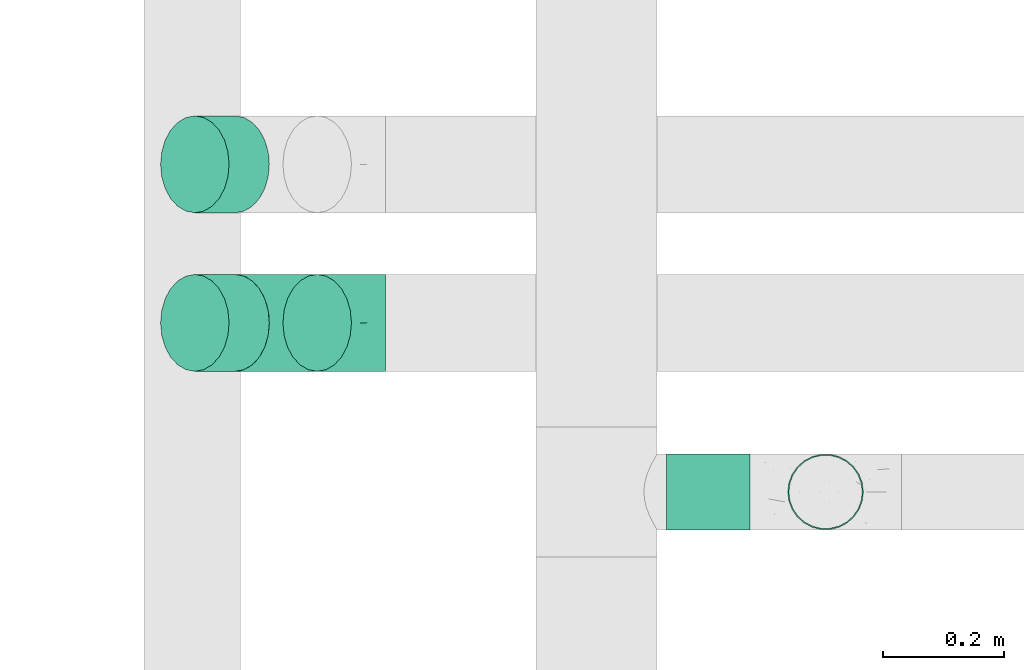
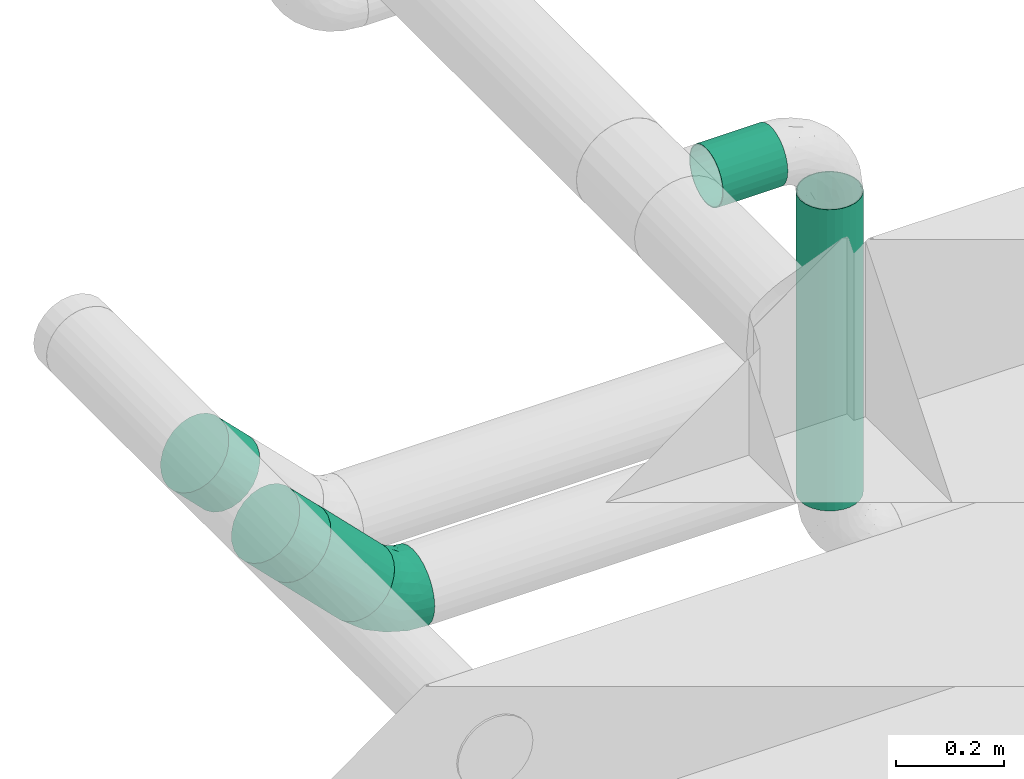
# One storey, part 62 of 91: 3 flow fittings, 3 flow segments.
"""IFC2X3 building model written with IfcOpenShell, lengths in millimetres."""

import ifcopenshell
import ifcopenshell.guid

model = None  # the IFC model being written
_history = None  # IfcOwnerHistory: only IFC2X3 demands one
_inside = {}  # id of a spatial element -> (the spatial element, [elements in it])
_under = {}  # id of a project, library or spatial element -> (it, [spatial elements below it])
_declared = {}  # id of a project -> (the project, [libraries it declares])
_typed = {}  # id of a type object -> (the type object, [elements of that type])
_made_of = {}  # id of a material, layer set ... -> (it, [elements and type objects made of it])


def new_model(schema):
    """Start an empty IFC model of exactly this schema.

    Asked for "IFC4X3", IfcOpenShell would pick the latest addendum, in which some entities
    have other attributes; the version numbers below select the first issue.
    IFC2X3 requires an IfcOwnerHistory on every rooted entity: one is made here for all.
    """
    global model, _history
    if schema == "IFC4X3":
        model = ifcopenshell.file(schema_version=(4, 3, 0, 0))
    else:
        model = ifcopenshell.file(schema=schema)
    _inside.clear()
    _under.clear()
    _declared.clear()
    _typed.clear()
    _made_of.clear()
    _history = None
    if model.schema == "IFC2X3":
        org = make("IfcOrganization", Name="unknown")
        user = make(
            "IfcPersonAndOrganization",
            ThePerson=make("IfcPerson", FamilyName="unknown"),
            TheOrganization=org,
        )
        app = make(
            "IfcApplication",
            ApplicationDeveloper=org,
            Version="unknown",
            ApplicationFullName="unknown",
            ApplicationIdentifier="unknown",
        )
        _history = make(
            "IfcOwnerHistory",
            OwningUser=user,
            OwningApplication=app,
            ChangeAction="ADDED",
            CreationDate=0,
        )
    return model


def make(cls, **values):
    """One entity of the class cls with the attributes given. An attribute that is None is left unset."""
    return model.create_entity(
        cls, **{name: value for name, value in values.items() if value is not None}
    )


def entity(cls, *values):
    """Any entity or typed value of the class cls, its attributes in the order of the schema. None: left unset."""
    e = model.create_entity(cls)
    for i, value in enumerate(values):
        if value is not None:
            e[i] = value
    return e


def rooted(cls, **values):
    """An entity with a GlobalId (a new one), such as an element, a storey or a relation."""
    return make(cls, GlobalId=ifcopenshell.guid.new(), OwnerHistory=_history, **values)


def si_unit(unit_type, name, prefix=None):
    """IfcSIUnit, for example si_unit("LENGTHUNIT", "METRE", prefix="MILLI")."""
    return make("IfcSIUnit", UnitType=unit_type, Prefix=prefix, Name=name)


def converted_unit(unit_type, name, factor, base, dimensions=None, offset=None):
    """IfcConversionBasedUnit, such as the inch: factor (a typed value) times the base unit."""
    return make(
        "IfcConversionBasedUnit"
        if offset is None
        else "IfcConversionBasedUnitWithOffset",
        ConversionOffset=offset,
        Dimensions=None
        if dimensions is None
        else entity("IfcDimensionalExponents", *dimensions),
        UnitType=unit_type,
        Name=name,
        ConversionFactor=make(
            "IfcMeasureWithUnit", ValueComponent=factor, UnitComponent=base
        ),
    )


def derived_unit(unit_type, elements):
    """IfcDerivedUnit: a product of units, each with its exponent."""
    return make(
        "IfcDerivedUnit",
        Elements=[
            make("IfcDerivedUnitElement", Unit=unit, Exponent=power)
            for unit, power in elements
        ],
        UnitType=unit_type,
    )


def assignment(units):
    """IfcUnitAssignment: the units of a project."""
    return None if units is None else make("IfcUnitAssignment", Units=units)


def point(xyz):
    """IfcCartesianPoint."""
    return None if xyz is None else make("IfcCartesianPoint", Coordinates=xyz)


def direction(xyz):
    """IfcDirection."""
    return None if xyz is None else make("IfcDirection", DirectionRatios=xyz)


def frame(location, z_axis=None, x_axis=None):
    """IfcAxis2Placement3D, a coordinate frame: its origin and axes. An axis left out is left unset."""
    return make(
        "IfcAxis2Placement3D",
        Location=point(location),
        Axis=direction(z_axis),
        RefDirection=direction(x_axis),
    )


def frame_2d(location, x_axis=None):
    """IfcAxis2Placement2D, a coordinate frame in the plane: its origin and x axis."""
    return make(
        "IfcAxis2Placement2D", Location=point(location), RefDirection=direction(x_axis)
    )


def origin_with_axes():
    """The frame at (0, 0, 0) with the z axis (0, 0, 1) and the x axis (1, 0, 0) written out."""
    return frame((0.0, 0.0, 0.0), z_axis=(0.0, 0.0, 1.0), x_axis=(1.0, 0.0, 0.0))


def origin_2d_with_axis():
    """The frame at (0, 0) in the plane with the x axis (1, 0) written out."""
    return frame_2d((0.0, 0.0), x_axis=(1.0, 0.0))


def place(relative_to, where):
    """IfcLocalPlacement: puts the frame where relative to a parent placement (None: the world)."""
    return make(
        "IfcLocalPlacement", PlacementRelTo=relative_to, RelativePlacement=where
    )


def context(
    kind, dimensions, precision=None, world=None, true_north=None, identifier=None
):
    """IfcGeometricRepresentationContext, for example the 3D "Model" context."""
    return make(
        "IfcGeometricRepresentationContext",
        ContextIdentifier=identifier,
        ContextType=kind,
        CoordinateSpaceDimension=dimensions,
        Precision=precision,
        WorldCoordinateSystem=world,
        TrueNorth=true_north,
    )


def subcontext(parent, identifier, kind, view, scale=None):
    """IfcGeometricRepresentationSubContext, for example "Body" below "Model"."""
    return make(
        "IfcGeometricRepresentationSubContext",
        ContextIdentifier=identifier,
        ContextType=kind,
        ParentContext=parent,
        TargetScale=scale,
        TargetView=view,
    )


def project(units=None, contexts=None):
    """IfcProject with its units and contexts."""
    return rooted(
        "IfcProject",
        Name="project",
        RepresentationContexts=contexts,
        UnitsInContext=assignment(units),
    )


def spatial(cls, under=None, at=None, **own):
    """A site, building, storey or space (cls), placed at a placement, below another one or the project."""
    s = rooted(cls, ObjectPlacement=at, **own)
    if under is not None:
        _under.setdefault(under.id(), (under, []))[1].append(s)
    return s


def profile(cls, at=None, kind="AREA", **sizes):
    """A parametric profile (cls). Its sizes go by their IFC names, for example OverallWidth=200.0."""
    return make(cls, ProfileType=kind, Position=at, **sizes)


def hollow_circle(**sizes):
    """IfcCircleHollowProfileDef."""
    return profile("IfcCircleHollowProfileDef", **sizes)


def extrude(swept, where, along, depth):
    """IfcExtrudedAreaSolid: the profile swept, set in the frame where, extruded along a direction by depth."""
    return make(
        "IfcExtrudedAreaSolid",
        SweptArea=swept,
        Position=where,
        ExtrudedDirection=direction(along),
        Depth=depth,
    )


def faces_of(points, faces, orient=None, outer=None):
    """IfcFace entities. A face is a list of loops; a loop is a list of indices into points, from 0.

    orient and outer hold one flag for each loop. By default every Orientation is true, the
    first loop of a face is its IfcFaceOuterBound and the others are IfcFaceBound.
    """
    made = []
    for i, loops in enumerate(faces):
        bounds = []
        for j, loop in enumerate(loops):
            is_outer = j == 0 if outer is None else outer[i][j]
            bounds.append(
                make(
                    "IfcFaceOuterBound" if is_outer else "IfcFaceBound",
                    Bound=make("IfcPolyLoop", Polygon=[points[k] for k in loop]),
                    Orientation=True if orient is None else orient[i][j],
                )
            )
        made.append(make("IfcFace", Bounds=bounds))
    return made


def open_shell(faces, orient=None, outer=None):
    """The faces of one IfcOpenShell. surface_model builds it on its shared points."""
    return ("IfcOpenShell", faces, orient, outer)


def surface_model(cls, points, shells):
    """IfcFaceBasedSurfaceModel or IfcShellBasedSurfaceModel (cls): surfaces that need not close."""
    shared = [point(p) for p in points]
    made = [make(c, CfsFaces=faces_of(shared, fs, o, b)) for c, fs, o, b in shells]
    if cls == "IfcFaceBasedSurfaceModel":
        return make(cls, FbsmFaces=made)
    return make(cls, SbsmBoundary=made)


def shape(context_of_items, identifier, shape_type, items):
    """IfcShapeRepresentation: the items that make up one representation, for example the "Body"."""
    return make(
        "IfcShapeRepresentation",
        ContextOfItems=context_of_items,
        RepresentationIdentifier=identifier,
        RepresentationType=shape_type,
        Items=items,
    )


def source(mapping_origin, context_of_items, identifier, shape_type, items):
    """IfcRepresentationMap: a shape defined once, which mapped items show again and again."""
    return make(
        "IfcRepresentationMap",
        MappingOrigin=mapping_origin,
        MappedRepresentation=shape(context_of_items, identifier, shape_type, items),
    )


def transform(
    local_origin,
    x_axis=None,
    y_axis=None,
    z_axis=None,
    scale=None,
    scale2=None,
    scale3=None,
    uniform=True,
):
    """IfcCartesianTransformationOperator3D, or its non-uniform kind. x_axis, y_axis, z_axis: its Axis1, 2, 3."""
    if uniform:
        return make(
            "IfcCartesianTransformationOperator3D",
            Axis1=direction(x_axis),
            Axis2=direction(y_axis),
            LocalOrigin=point(local_origin),
            Scale=scale,
            Axis3=direction(z_axis),
        )
    return make(
        "IfcCartesianTransformationOperator3DnonUniform",
        Axis1=direction(x_axis),
        Axis2=direction(y_axis),
        LocalOrigin=point(local_origin),
        Scale=scale,
        Axis3=direction(z_axis),
        Scale2=scale2,
        Scale3=scale3,
    )


def mapped(mapping_source, mapping_target):
    """IfcMappedItem: shows the shape of a source again, moved by a transform."""
    return make(
        "IfcMappedItem", MappingSource=mapping_source, MappingTarget=mapping_target
    )


def material(Name=None, Category=None):
    """IfcMaterial."""
    return make("IfcMaterial", Name=Name, Category=Category)


def layer(
    of_material, thickness, ventilated=None, Name=None, Category=None, Priority=None
):
    """IfcMaterialLayer: one layer of a wall or slab, of a material (None: an air gap)."""
    return make(
        "IfcMaterialLayer",
        Material=of_material,
        LayerThickness=thickness,
        IsVentilated=ventilated,
        Name=Name,
        Category=Category,
        Priority=Priority,
    )


def layer_set(layers, Name=None):
    """IfcMaterialLayerSet."""
    return make("IfcMaterialLayerSet", MaterialLayers=layers, LayerSetName=Name)


def layer_usage(for_layer_set, set_direction, sense, offset, extent=None):
    """IfcMaterialLayerSetUsage: how a layer set lies in its element."""
    return make(
        "IfcMaterialLayerSetUsage",
        ForLayerSet=for_layer_set,
        LayerSetDirection=set_direction,
        DirectionSense=sense,
        OffsetFromReferenceLine=offset,
        ReferenceExtent=extent,
    )


def made_of(thing, what):
    """Note that an element or type object is made of a material, layer set ...; save() writes the relation."""
    if what is not None:
        _made_of.setdefault(what.id(), (what, []))[1].append(thing)
    return thing


def type_object(cls, material=None, **own):
    """A type object (cls), such as IfcWallType, which elements share."""
    return made_of(rooted(cls, **own), material)


def element(
    cls,
    number,
    at=None,
    inside=None,
    cuts=None,
    type_object=None,
    material=None,
    context=None,
    identifier="Body",
    shape_type=None,
    held_by="IfcProductDefinitionShape",
    body=None,
    shapes=None,
    **own,
):
    """One element of the class cls, such as IfcWall. Its Tag is "e" and its number.

    at: its placement. inside: the storey or other place that contains it. cuts: it is an
    opening in that element (IfcRelVoidsElement). A single representation is given by context,
    identifier, shape_type and body (its items); several are given by shapes. held_by: the class
    of the entity that holds the representations. save() writes the other relations.
    """
    e = rooted(cls, Tag="e%d" % number, ObjectPlacement=at, **own)
    if body is not None:
        shapes = [shape(context, identifier, shape_type, body)]
    if shapes is not None:
        e.Representation = make(held_by, Representations=shapes)
    if inside is not None:
        _inside.setdefault(inside.id(), (inside, []))[1].append(e)
    if cuts is not None:
        rooted(
            "IfcRelVoidsElement", RelatingBuildingElement=cuts, RelatedOpeningElement=e
        )
    if type_object is not None:
        _typed.setdefault(type_object.id(), (type_object, []))[1].append(e)
    return made_of(e, material)


def aggregate(whole, parts):
    """IfcRelAggregates: a whole, such as a stair, and the parts it consists of."""
    return rooted("IfcRelAggregates", RelatingObject=whole, RelatedObjects=parts)


def save(model, path):
    """Write the relations noted so far, then the file.

    IfcRelAggregates (storeys below a building ...), IfcRelContainedInSpatialStructure (elements
    in a storey), IfcRelDefinesByType, IfcRelAssociatesMaterial and IfcRelDeclares: one each for
    every whole, place, type object, material and project.
    """
    for whole, parts in _under.values():
        aggregate(whole, parts)
    for where, things in _inside.values():
        rooted(
            "IfcRelContainedInSpatialStructure",
            RelatedElements=things,
            RelatingStructure=where,
        )
    for kind, things in _typed.values():
        rooted("IfcRelDefinesByType", RelatedObjects=things, RelatingType=kind)
    for what, things in _made_of.values():
        rooted("IfcRelAssociatesMaterial", RelatedObjects=things, RelatingMaterial=what)
    for by, libraries in _declared.values():
        rooted("IfcRelDeclares", RelatingContext=by, RelatedDefinitions=libraries)
    model.write(path)


model = new_model("IFC2X3")

# Units and contexts
model_context = context("Model", 3, precision=1e-05, world=origin_with_axes(), true_north=direction((0.0, 1.0)))
body_context = subcontext(model_context, "Body", "Model", "MODEL_VIEW")
ifc_project = project(units=[si_unit("AREAUNIT", "SQUARE_METRE"), si_unit("VOLUMEUNIT", "CUBIC_METRE", prefix="DECI"), si_unit("TIMEUNIT", "SECOND"), si_unit("THERMODYNAMICTEMPERATUREUNIT", "DEGREE_CELSIUS"), si_unit("PRESSUREUNIT", "PASCAL"), si_unit("MASSUNIT", "GRAM", prefix="KILO"), si_unit("LENGTHUNIT", "METRE", prefix="MILLI"), si_unit("POWERUNIT", "WATT"), si_unit("ELECTRICCURRENTUNIT", "AMPERE"), si_unit("ELECTRICVOLTAGEUNIT", "VOLT"), derived_unit("VOLUMETRICFLOWRATEUNIT", [(si_unit("VOLUMEUNIT", "CUBIC_METRE", prefix="DECI"), 1), (si_unit("TIMEUNIT", "SECOND"), -1)]), derived_unit("LINEARVELOCITYUNIT", [(si_unit("LENGTHUNIT", "METRE"), 1), (si_unit("TIMEUNIT", "SECOND"), -1)]), derived_unit("MASSDENSITYUNIT", [(si_unit("MASSUNIT", "GRAM", prefix="KILO"), 1), (si_unit("VOLUMEUNIT", "CUBIC_METRE"), -1)]), converted_unit("PLANEANGLEUNIT", "DEGREE", entity("IfcRatioMeasure", 0.01745), si_unit("PLANEANGLEUNIT", "RADIAN"), dimensions=[0, 0, 0, 0, 0, 0, 0])], contexts=[model_context])

# Site, building, storey
site_placement = place(None, origin_with_axes())
site = spatial("IfcSite", under=ifc_project, at=site_placement, CompositionType="ELEMENT")
building_placement = place(site_placement, origin_with_axes())
building = spatial("IfcBuilding", under=site, at=building_placement, Name="mc-building", CompositionType="ELEMENT")
storey_placement = place(building_placement, frame((0.0, 0.0, 8700.0), z_axis=(0.0, 0.0, 1.0), x_axis=(1.0, 0.0, 0.0)))
storey = spatial("IfcBuildingStorey", under=building, at=storey_placement, CompositionType="ELEMENT", Elevation=8700.0)

# Flow segments
ifc_material = material(Name="FZ1")
ifc_layer = layer(ifc_material, 0.0)
ifc_layer_set = layer_set([ifc_layer], Name="FZ1")
ifc_layer_usage = layer_usage(ifc_layer_set, "AXIS1", "POSITIVE", 0.0)
duct_segment_type_1 = type_object("IfcDuctSegmentType", Name="Safe", PredefinedType="RIGIDSEGMENT")
shared_shape_1 = source(origin_with_axes(), body_context, "Body", "SweptSolid", [
    extrude(hollow_circle(Radius=62.5, WallThickness=2.0, at=origin_2d_with_axis()), frame((0.0, 0.0, 0.0), z_axis=(1.0, 0.0, 0.0), x_axis=(0.0, 1.0, 0.0)), (0.0, 0.0, 1.0), 679.0),
])
flow_segment_1_placement = place(storey_placement, frame((33742.76981, 4322.30408, 1219.0), z_axis=(0.0, 1.0, 0.0), x_axis=(0.0, 0.0, -1.0)))
element("IfcFlowSegment", 1, at=flow_segment_1_placement, inside=storey, type_object=duct_segment_type_1, material=ifc_layer_usage, Name="Safe", context=body_context, shape_type="MappedRepresentation", body=[
    mapped(shared_shape_1, transform((0.0, 0.0, 0.0), scale=1.0)),
])
shared_shape_2 = source(origin_with_axes(), body_context, "Body", "SweptSolid", [
    extrude(hollow_circle(Radius=62.5, WallThickness=2.0, at=origin_2d_with_axis()), frame((0.0, 0.0, 0.0), z_axis=(1.0, 0.0, 0.0), x_axis=(0.0, 1.0, 0.0)), (0.0, 0.0, 1.0), 138.0),
])
flow_segment_2_placement = place(storey_placement, frame((33479.76981, 4322.30408, 1344.0), z_axis=(0.0, 0.0, 1.0), x_axis=(1.0, 0.0, 0.0)))
element("IfcFlowSegment", 2, at=flow_segment_2_placement, inside=storey, type_object=duct_segment_type_1, material=ifc_layer_usage, Name="Safe", context=body_context, shape_type="MappedRepresentation", body=[
    mapped(shared_shape_2, transform((0.0, 0.0, 0.0), scale=1.0)),
])
duct_segment_type_2 = type_object("IfcDuctSegmentType", PredefinedType="RIGIDSEGMENT")
shared_shape_3 = source(origin_with_axes(), body_context, "Body", "SweptSolid", [
    extrude(hollow_circle(Radius=80.0, WallThickness=2.0, at=origin_2d_with_axis()), frame((0.0, 0.0, 0.0), z_axis=(1.0, 0.0, 0.0), x_axis=(0.0, 1.0, 0.0)), (0.0, 0.0, 1.0), 191.8),
])
flow_segment_3_placement = place(storey_placement, frame((32767.76309, 4601.38149, 597.28932), z_axis=(-0.707107, 0.0, -0.707107), x_axis=(0.707107, 0.0, -0.707107)))
element("IfcFlowSegment", 3, at=flow_segment_3_placement, inside=storey, type_object=duct_segment_type_2, material=ifc_layer_usage, context=body_context, shape_type="MappedRepresentation", body=[
    mapped(shared_shape_3, transform((0.0, 0.0, 0.0), scale=1.0)),
])

# Flow fittings
duct_fitting_type_1 = type_object("IfcDuctFittingType", Name="BU", PredefinedType="BEND")
shared_shape_4 = source(origin_with_axes(), body_context, "Body", "SurfaceModel", [
    surface_model("IfcShellBasedSurfaceModel", [(-66.0, 0.0, -80.0), (-66.0, -20.70552, -77.27406), (-66.0, 20.70552, -77.27406), (-66.0, 77.27406, 20.70552), (-66.0, 40.0, -69.28203), (-66.0, 69.28203, -40.0), (-66.0, 56.56854, -56.56854), (-66.0, -80.0, 0.0), (-66.0, -77.27406, 20.70552), (-66.0, -56.56854, -56.56854), (-66.0, -40.0, -69.28203), (-66.0, -77.27406, -20.70552), (-66.0, -69.28203, -40.0), (-66.0, 77.27406, -20.70552), (-66.0, 69.28203, 40.0), (-66.0, 56.56854, 56.56854), (-66.0, 40.0, 69.28203), (-66.0, 20.70552, 77.27406), (-66.0, 0.0, 80.0), (-66.0, -69.28203, 40.0), (-66.0, -56.56854, 56.56854), (-66.0, -40.0, 69.28203), (-66.0, -20.70552, 77.27406), (-66.0, 80.0, 0.0), (32.02803, 61.31007, -77.27406), (-7.97197, 101.31007, 20.70552), (46.66905, 46.66905, -80.0), (18.38478, 74.95332, -69.28203), (-9.89949, 103.23759, 0.0), (6.66905, 86.66905, -56.56854), (-2.32075, 95.65884, -40.0), (86.66905, 6.66905, -56.56854), (101.31007, -7.97197, 20.70552), (74.95332, 18.38478, -69.28203), (61.31007, 32.02803, -77.27406), (95.65884, -2.32075, -40.0), (101.31007, -7.97197, -20.70552), (103.23759, -9.89949, 0.0), (-7.97197, 101.31007, -20.70552), (6.66905, 86.66905, 56.56854), (-2.32075, 95.65884, 40.0), (32.02803, 61.31007, 77.27406), (18.38478, 74.95332, 69.28203), (46.66905, 46.66905, 80.0), (95.65884, -2.32075, 40.0), (86.66905, 6.66905, 56.56854), (61.31007, 32.02803, 77.27406), (74.95332, 18.38478, 69.28203), (-29.3122, 70.76593, 48.70091), (-39.11736, 52.01657, 63.46827), (-10.68141, 63.52348, 63.46827), (-24.76027, 5.42931, 80.0), (-26.0988, 22.44327, 78.22754), (-43.64741, 32.57027, 73.91036), (-11.01132, 80.80613, 48.70092), (-23.28613, 85.35551, 30.61467), (-45.24276, 76.47052, 30.61467), (-26.72501, 88.70772, 15.3046), (-41.60923, 82.30385, 15.24127), (-49.35238, 64.92474, 48.70092), (-16.73968, 40.41316, 73.91036), (1.70507, 33.61491, 78.27077), (-48.94647, 83.39216, 0.0), (7.83434, 53.87497, 73.91722), (-35.63862, 86.03925, 0.0), (-24.35678, 93.57754, 0.0), (13.66905, 21.34726, 80.0), (-9.12112, 64.44142, -63.46827), (7.83434, 53.87497, -73.91722), (-49.35238, 64.92474, -48.70092), (13.66905, 21.34726, -80.0), (-24.76027, 5.42931, -80.0), (1.70507, 33.61491, -78.27077), (-16.73968, 40.41316, -73.91036), (-43.64741, 32.57027, -73.91036), (-37.36499, 52.47078, -63.46827), (-43.88968, 76.82125, -30.61467), (-29.3122, 70.76593, -48.70091), (-11.01132, 80.80613, -48.70092), (-26.0988, 22.44327, -78.22754), (-41.61933, 82.33577, -15.06774), (-20.69354, 92.29426, -15.81526), (-22.08137, 86.06429, -30.61467), (4.66665, -11.26628, -75.88648), (4.53012, -26.29481, -69.71414), (-10.03915, -42.81559, -62.11279), (-26.71074, -60.68241, -47.78211), (1.93839, -66.36167, -23.84046), (46.43525, -50.50882, -14.18656), (25.59072, -61.78147, 0.0), (55.70521, -40.12697, -29.59367), (19.85152, -47.92581, -46.63308), (-19.30745, -75.40118, 0.0), (42.53881, -19.93692, -62.2624), (61.79629, -24.0216, -47.78211), (66.96912, -39.66426, 0.0), (38.90646, -5.30204, -71.50052), (61.79629, -24.0216, 47.78211), (-26.71074, -60.68241, 47.78211), (1.93839, -66.36167, 23.84046), (46.43525, -50.50882, 14.18656), (15.38995, -21.79652, 69.71414), (-15.98195, -44.17702, 62.2624), (19.85152, -47.92581, 46.63308), (37.37394, -23.17644, 62.11279), (4.66665, -11.26628, 75.88648), (55.70521, -40.12697, 29.59367), (-23.76192, -31.26014, 71.50052)], [open_shell([[[0, 1, 2]], [[2, 3, 4]], [[5, 6, 3]], [[4, 3, 6]], [[2, 7, 8]], [[9, 7, 10]], [[2, 1, 10]], [[11, 7, 12]], [[9, 12, 7]], [[10, 7, 2]], [[5, 3, 13]], [[2, 14, 3]], [[15, 14, 2]], [[16, 2, 17]], [[16, 15, 2]], [[17, 2, 18]], [[19, 20, 2]], [[2, 8, 19]], [[21, 22, 2]], [[2, 20, 21]], [[18, 2, 22]], [[23, 13, 3]], [[24, 25, 26]], [[27, 28, 24]], [[29, 30, 28]], [[29, 28, 27]], [[31, 26, 32]], [[26, 31, 33]], [[33, 34, 26]], [[35, 32, 36]], [[32, 35, 31]], [[36, 32, 37]], [[28, 30, 38]], [[39, 26, 25]], [[39, 25, 40]], [[41, 26, 42]], [[26, 39, 42]], [[43, 26, 41]], [[26, 44, 32]], [[45, 44, 26]], [[46, 47, 26]], [[45, 26, 47]], [[26, 43, 46]], [[25, 24, 28]], [[48, 49, 50]], [[18, 51, 52]], [[16, 49, 15]], [[53, 16, 17]], [[49, 16, 53]], [[54, 50, 39]], [[48, 55, 56]], [[55, 57, 58]], [[59, 14, 15]], [[60, 53, 52]], [[50, 49, 60]], [[58, 3, 56]], [[52, 51, 61]], [[62, 23, 3]], [[63, 50, 60]], [[50, 42, 39]], [[3, 58, 62]], [[41, 61, 43]], [[62, 58, 64]], [[48, 59, 49]], [[14, 56, 3]], [[39, 40, 54]], [[57, 64, 58]], [[40, 25, 55]], [[63, 60, 61]], [[54, 55, 48]], [[65, 57, 25]], [[56, 14, 59]], [[25, 28, 65]], [[60, 52, 61]], [[49, 59, 15]], [[55, 58, 56]], [[56, 59, 48]], [[55, 54, 40]], [[50, 54, 48]], [[17, 18, 52]], [[49, 53, 60]], [[17, 52, 53]], [[61, 51, 66]], [[43, 61, 66]], [[63, 61, 41]], [[41, 42, 63]], [[50, 63, 42]], [[25, 57, 55]], [[64, 57, 65]], [[67, 27, 68]], [[69, 6, 5]], [[70, 71, 72]], [[73, 74, 75]], [[76, 77, 69]], [[29, 78, 30]], [[2, 79, 0]], [[13, 23, 62]], [[2, 74, 79]], [[6, 75, 4]], [[77, 78, 67]], [[13, 62, 80]], [[64, 80, 62]], [[81, 80, 64]], [[67, 73, 75]], [[82, 77, 76]], [[81, 64, 65]], [[76, 69, 5]], [[82, 76, 80]], [[24, 72, 68]], [[74, 2, 4]], [[27, 67, 29]], [[26, 70, 72]], [[69, 75, 6]], [[82, 30, 78]], [[72, 71, 79]], [[5, 13, 76]], [[77, 67, 75]], [[13, 80, 76]], [[82, 38, 30]], [[81, 28, 38]], [[82, 81, 38]], [[75, 69, 77]], [[67, 78, 29]], [[82, 78, 77]], [[75, 74, 4]], [[79, 74, 73]], [[79, 73, 72]], [[79, 71, 0]], [[68, 72, 73]], [[26, 72, 24]], [[67, 68, 73]], [[27, 24, 68]], [[80, 81, 82]], [[28, 81, 65]], [[1, 83, 84]], [[85, 86, 9]], [[0, 71, 1]], [[87, 88, 89]], [[36, 88, 90]], [[86, 85, 91]], [[7, 11, 92]], [[84, 93, 85]], [[86, 87, 12]], [[90, 94, 35]], [[9, 86, 12]], [[87, 92, 11]], [[93, 94, 91]], [[10, 85, 9]], [[83, 71, 70]], [[87, 86, 91]], [[70, 26, 34]], [[93, 31, 94]], [[33, 31, 93]], [[88, 36, 95]], [[93, 96, 33]], [[71, 83, 1]], [[91, 90, 87]], [[35, 94, 31]], [[33, 96, 34]], [[90, 88, 87]], [[36, 37, 95]], [[94, 90, 91]], [[12, 87, 11]], [[89, 88, 95]], [[92, 87, 89]], [[91, 85, 93]], [[84, 10, 1]], [[70, 34, 83]], [[96, 84, 83]], [[35, 36, 90]], [[34, 96, 83]], [[93, 84, 96]], [[10, 84, 85]], [[45, 97, 44]], [[8, 7, 92]], [[20, 19, 98]], [[99, 8, 92]], [[19, 8, 99]], [[89, 95, 100]], [[101, 47, 46]], [[102, 103, 104]], [[22, 51, 18]], [[51, 22, 105]], [[99, 89, 100]], [[106, 44, 97]], [[21, 20, 102]], [[102, 107, 21]], [[89, 99, 92]], [[99, 103, 98]], [[106, 100, 32]], [[107, 22, 21]], [[103, 99, 106]], [[32, 95, 37]], [[106, 97, 103]], [[104, 97, 45]], [[46, 105, 101]], [[45, 47, 104]], [[107, 101, 105]], [[43, 66, 46]], [[105, 66, 51]], [[66, 105, 46]], [[99, 98, 19]], [[99, 100, 106]], [[97, 104, 103]], [[32, 100, 95]], [[102, 98, 103]], [[32, 44, 106]], [[101, 102, 104]], [[102, 20, 98]], [[22, 107, 105]], [[102, 101, 107]], [[47, 101, 104]]])]),
])
flow_fitting_placement = place(storey_placement, frame((32950.05242, 4601.38149, 415.0), z_axis=(0.0, 1.0, 0.0), x_axis=(-1.0, 0.0, 0.0)))
element("IfcFlowFitting", 4, at=flow_fitting_placement, inside=storey, type_object=duct_fitting_type_1, Name="BU", context=body_context, shape_type="MappedRepresentation", body=[
    mapped(shared_shape_4, transform((0.0, 0.0, 0.0), scale=1.0)),
])
duct_fitting_type_2 = type_object("IfcDuctFittingType", Name="CC", PredefinedType="CONNECTOR")
shared_shape_5 = source(origin_with_axes(), body_context, "Body", "SurfaceModel", [
    surface_model("IfcShellBasedSurfaceModel", [(20.0, 80.0, 0.0), (20.0, 0.0, -80.0), (20.0, 20.70552, -77.27406), (20.0, 40.0, -69.28203), (20.0, 56.56854, -56.56854), (20.0, 69.28203, -40.0), (20.0, -56.56854, -56.56854), (20.0, -77.27406, 20.70552), (20.0, -40.0, -69.28203), (20.0, -20.70552, -77.27406), (20.0, -69.28203, -40.0), (20.0, -77.27406, -20.70552), (20.0, -80.0, 0.0), (20.0, 77.27406, -20.70552), (20.0, 69.28203, 40.0), (20.0, 77.27406, 20.70552), (20.0, 56.56854, 56.56854), (20.0, 40.0, 69.28203), (20.0, 20.70552, 77.27406), (20.0, 0.0, 80.0), (20.0, -69.28203, 40.0), (20.0, -56.56854, 56.56854), (20.0, -40.0, 69.28203), (20.0, -20.70552, 77.27406), (0.0, 0.0, 80.0), (0.0, 20.70552, 77.27406), (0.0, 40.0, 69.28203), (0.0, 56.56854, 56.56854), (0.0, 69.28203, 40.0), (0.0, 77.27406, 20.70552), (0.0, 80.0, 0.0), (0.0, 77.27406, -20.70552), (0.0, 69.28203, -40.0), (0.0, 56.56854, -56.56854), (0.0, 0.0, -80.0), (0.0, 40.0, -69.28203), (0.0, 20.70552, -77.27406), (0.0, -20.70552, -77.27406), (0.0, -40.0, -69.28203), (0.0, -56.56854, -56.56854), (0.0, -69.28203, -40.0), (0.0, -77.27406, -20.70552), (0.0, -80.0, 0.0), (0.0, -77.27406, 20.70552), (0.0, -69.28203, 40.0), (0.0, -56.56854, 56.56854), (0.0, -40.0, 69.28203), (0.0, -20.70552, 77.27406), (-73.904, 0.0, -80.0), (-73.904, -20.70552, -77.27406), (-73.904, 20.70552, -77.27406), (-73.904, 77.27406, 20.70552), (-73.904, 40.0, -69.28203), (-73.904, 69.28203, -40.0), (-73.904, 56.56854, -56.56854), (-73.904, -80.0, 0.0), (-73.904, -77.27406, 20.70552), (-73.904, -56.56854, -56.56854), (-73.904, -40.0, -69.28203), (-73.904, -77.27406, -20.70552), (-73.904, -69.28203, -40.0), (-73.904, 77.27406, -20.70552), (-73.904, 69.28203, 40.0), (-73.904, 56.56854, 56.56854), (-73.904, 20.70552, 77.27406), (-73.904, 40.0, 69.28203), (-73.904, 0.0, 80.0), (-73.904, -69.28203, 40.0), (-73.904, -56.56854, 56.56854), (-73.904, -40.0, 69.28203), (-73.904, -20.70552, 77.27406), (-73.904, 80.0, 0.0)], [open_shell([[[0, 1, 2]], [[3, 0, 2]], [[0, 4, 5]], [[4, 0, 3]], [[6, 1, 7]], [[1, 6, 8]], [[8, 9, 1]], [[6, 7, 10]], [[10, 7, 11]], [[12, 11, 7]], [[13, 0, 5]], [[14, 1, 15]], [[1, 14, 16]], [[17, 18, 1]], [[1, 16, 17]], [[18, 19, 1]], [[1, 20, 7]], [[21, 20, 1]], [[1, 22, 21]], [[22, 1, 23]], [[19, 23, 1]], [[1, 0, 15]], [[24, 19, 18]], [[25, 18, 17]], [[24, 18, 25]], [[26, 16, 27]], [[26, 25, 17]], [[16, 26, 17]], [[28, 14, 15]], [[29, 15, 0]], [[27, 14, 28]], [[29, 28, 15]], [[30, 29, 0]], [[14, 27, 16]], [[30, 0, 13]], [[31, 13, 5]], [[30, 13, 31]], [[32, 4, 33]], [[32, 31, 5]], [[4, 32, 5]], [[2, 1, 34]], [[3, 2, 35]], [[33, 3, 35]], [[36, 35, 2]], [[34, 36, 2]], [[3, 33, 4]], [[34, 1, 9]], [[37, 9, 8]], [[34, 9, 37]], [[38, 6, 39]], [[38, 37, 8]], [[6, 38, 8]], [[40, 10, 11]], [[41, 11, 12]], [[39, 10, 40]], [[41, 40, 11]], [[42, 41, 12]], [[10, 39, 6]], [[42, 12, 7]], [[43, 7, 20]], [[42, 7, 43]], [[44, 21, 45]], [[44, 43, 20]], [[21, 44, 20]], [[46, 22, 23]], [[47, 23, 19]], [[45, 22, 46]], [[47, 46, 23]], [[24, 47, 19]], [[22, 45, 21]], [[5, 0, 4]], [[10, 6, 7]], [[0, 5, 13]], [[14, 16, 1]], [[1, 18, 19]], [[7, 1, 20]], [[1, 23, 22]], [[15, 1, 0]], [[48, 49, 50]], [[50, 51, 52]], [[53, 54, 51]], [[52, 51, 54]], [[50, 55, 56]], [[57, 55, 58]], [[50, 49, 58]], [[59, 55, 60]], [[57, 60, 55]], [[58, 55, 50]], [[53, 51, 61]], [[62, 51, 50]], [[63, 62, 50]], [[50, 64, 65]], [[65, 63, 50]], [[66, 64, 50]], [[56, 67, 50]], [[50, 67, 68]], [[68, 69, 50]], [[70, 50, 69]], [[50, 70, 66]], [[71, 61, 51]], [[64, 24, 25]], [[65, 25, 26]], [[66, 24, 64]], [[64, 25, 65]], [[26, 63, 65]], [[26, 27, 63]], [[51, 28, 29]], [[71, 29, 30]], [[27, 62, 63]], [[27, 28, 62]], [[62, 28, 51]], [[29, 71, 51]], [[71, 30, 31]], [[61, 31, 32]], [[71, 31, 61]], [[33, 54, 53]], [[32, 53, 61]], [[53, 32, 33]], [[50, 35, 36]], [[48, 36, 34]], [[33, 52, 54]], [[33, 35, 52]], [[52, 35, 50]], [[36, 48, 50]], [[37, 38, 58]], [[34, 37, 49]], [[49, 48, 34]], [[58, 49, 37]], [[38, 57, 58]], [[38, 39, 57]], [[59, 40, 41]], [[55, 41, 42]], [[39, 60, 57]], [[39, 40, 60]], [[60, 40, 59]], [[41, 55, 59]], [[56, 42, 43]], [[67, 43, 44]], [[55, 42, 56]], [[56, 43, 67]], [[44, 68, 67]], [[44, 45, 68]], [[70, 46, 47]], [[66, 47, 24]], [[45, 69, 68]], [[45, 46, 69]], [[69, 46, 70]], [[47, 66, 70]], [[51, 50, 62]], [[50, 63, 62]], [[64, 65, 63]], [[63, 50, 64]], [[67, 50, 56]], [[69, 70, 50]]])]),
])
for number, where, z_axis, x_axis, name in (
    (5, (32753.62096, 4863.15068, 611.43146), (0.707107, 0.0, 0.707107), (0.707107, 0.0, -0.707107), "CC"),
    (6, (32753.62096, 4601.38149, 611.43146), (0.707107, 0.0, 0.707107), (0.707107, 0.0, -0.707107), "CC"),
):
    element("IfcFlowFitting", number, at=place(storey_placement, frame(where, z_axis=z_axis, x_axis=x_axis)), inside=storey, type_object=duct_fitting_type_2, Name=name, context=body_context, shape_type="MappedRepresentation", body=[
        mapped(shared_shape_5, transform((0.0, 0.0, 0.0), scale=1.0)),
    ])

save(model, "model.ifc")
